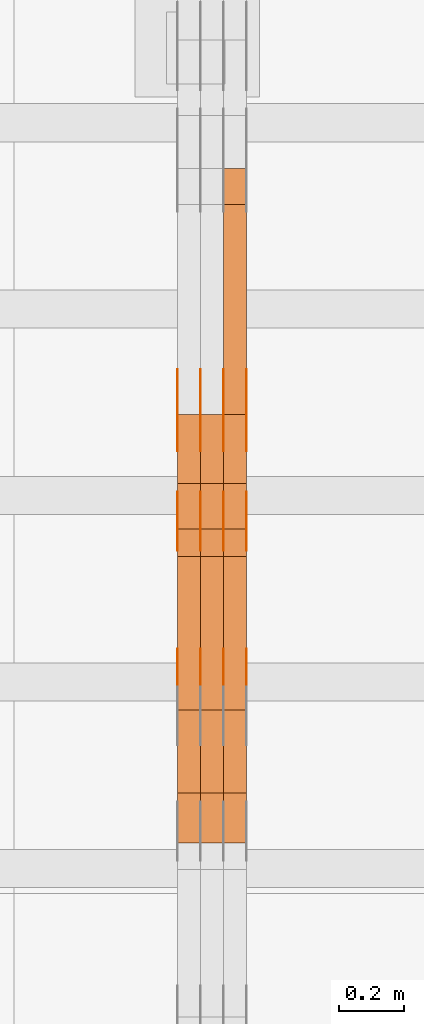
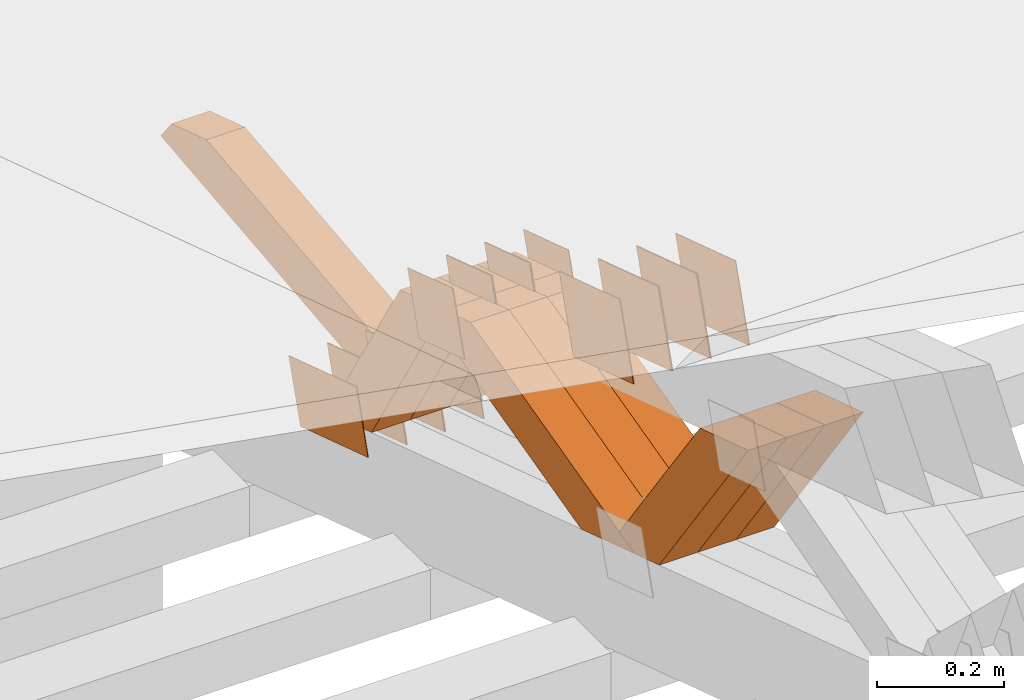
# One storey, part 241 of 385: 28 proxies.
"""IFC2X3 building model written with IfcOpenShell, lengths in millimetres."""

from ifc_helpers import new_model, entity, si_unit, converted_unit, derived_unit, direction, frame, origin, place, context, subcontext, project, spatial, polyline, outline, extrude, source, transform, mapped, material, type_object, type_shapes, element, save


model = new_model("IFC2X3")

# Units and contexts
model_context = context("Model", 3, precision=0.01, world=origin(), true_north=direction((6.12303176911189e-17, 1.0)))
body_context = subcontext(model_context, "Body", "Model", "MODEL_VIEW")
ifc_project = project(units=[si_unit("LENGTHUNIT", "METRE", prefix="MILLI"), si_unit("AREAUNIT", "SQUARE_METRE"), si_unit("VOLUMEUNIT", "CUBIC_METRE"), converted_unit("PLANEANGLEUNIT", "DEGREE", entity("IfcRatioMeasure", 0.0174532925199433), si_unit("PLANEANGLEUNIT", "RADIAN"), dimensions=[0, 0, 0, 0, 0, 0, 0]), si_unit("MASSUNIT", "GRAM", prefix="KILO"), derived_unit("MASSDENSITYUNIT", [(si_unit("MASSUNIT", "GRAM", prefix="KILO"), 1), (si_unit("LENGTHUNIT", "METRE"), -3)]), si_unit("TIMEUNIT", "SECOND"), si_unit("FREQUENCYUNIT", "HERTZ"), si_unit("THERMODYNAMICTEMPERATUREUNIT", "DEGREE_CELSIUS"), derived_unit("THERMALTRANSMITTANCEUNIT", [(si_unit("MASSUNIT", "GRAM", prefix="KILO"), 1), (si_unit("THERMODYNAMICTEMPERATUREUNIT", "KELVIN"), -1), (si_unit("TIMEUNIT", "SECOND"), -3)]), derived_unit("VOLUMETRICFLOWRATEUNIT", [(si_unit("LENGTHUNIT", "METRE"), 3), (si_unit("TIMEUNIT", "SECOND"), -1)]), si_unit("ELECTRICCURRENTUNIT", "AMPERE"), si_unit("ELECTRICVOLTAGEUNIT", "VOLT"), si_unit("POWERUNIT", "WATT"), si_unit("FORCEUNIT", "NEWTON", prefix="KILO"), si_unit("ILLUMINANCEUNIT", "LUX"), si_unit("LUMINOUSFLUXUNIT", "LUMEN"), si_unit("LUMINOUSINTENSITYUNIT", "CANDELA"), derived_unit("USERDEFINED", [(si_unit("MASSUNIT", "GRAM", prefix="KILO"), -1), (si_unit("LENGTHUNIT", "METRE"), -2), (si_unit("TIMEUNIT", "SECOND"), 3), (si_unit("LUMINOUSFLUXUNIT", "LUMEN"), 1)]), derived_unit("LINEARVELOCITYUNIT", [(si_unit("LENGTHUNIT", "METRE"), 1), (si_unit("TIMEUNIT", "SECOND"), -1)]), si_unit("PRESSUREUNIT", "PASCAL"), derived_unit("USERDEFINED", [(si_unit("LENGTHUNIT", "METRE"), -2), (si_unit("MASSUNIT", "GRAM", prefix="KILO"), 1), (si_unit("TIMEUNIT", "SECOND"), -2)])], contexts=[model_context])

# Site, building, storey
site_placement = place(None, origin())
site = spatial("IfcSite", under=ifc_project, at=site_placement, CompositionType="ELEMENT")
building_placement = place(site_placement, origin())
building = spatial("IfcBuilding", under=site, at=building_placement, CompositionType="ELEMENT")
storey_placement = place(building_placement, origin())
storey = spatial("IfcBuildingStorey", under=building, at=storey_placement, Name="Default", CompositionType="ELEMENT", Elevation=0.0)

# Proxies
ifc_material_1 = material(Name="IfcSurfaceStyle #366594")
building_element_proxy_type_1 = type_object("IfcBuildingElementProxyType", PredefinedType="NOTDEFINED", material=ifc_material_1)
shared_shape_1 = source(origin(), body_context, "Body", "SweptSolid", [
    extrude(outline(polyline([(-75.0001163267648, -60.0000309352964), (75.0001029049313, -60.0000309352964), (75.0001068963143, 60.0000309352964), (-75.0000934744807, 60.0000309352964), (-75.0001163267648, -60.0000309352964)])), frame((75.0001143227305, 60.0000309352964, 0.0), z_axis=(0.0, 0.0, 1.0), x_axis=(-1.0, 0.0, 0.0)), (0.0, 0.0, 1.0), 1.3),
])
type_shapes(building_element_proxy_type_1, [shared_shape_1])
proxy_1_placement = place(building_placement, frame((30386.3, 24935.0160969462, 827.753587802763), z_axis=(-1.0, 0.0, 0.0), x_axis=(0.0, -0.951056516295154, 0.309016994374948)))
element("IfcBuildingElementProxy", 1, at=proxy_1_placement, inside=storey, type_object=building_element_proxy_type_1, material=ifc_material_1, context=body_context, shape_type="MappedRepresentation", body=[
    mapped(shared_shape_1, transform((0.0, 0.0, 0.0), scale=1.0)),
])
ifc_material_2 = material(Name="IfcSurfaceStyle #366537")
building_element_proxy_type_2 = type_object("IfcBuildingElementProxyType", PredefinedType="NOTDEFINED", material=ifc_material_2)
shared_shape_2 = source(origin(), body_context, "Body", "SweptSolid", [
    extrude(outline(polyline([(-75.0001163267648, -60.0000309352964), (75.0001029049313, -60.0000309352964), (75.0001068963143, 60.0000309352964), (-75.0000934744807, 60.0000309352964), (-75.0001163267648, -60.0000309352964)])), frame((75.0001143227305, 60.0000309352964, 0.0), z_axis=(0.0, 0.0, 1.0), x_axis=(-1.0, 0.0, 0.0)), (0.0, 0.0, 1.0), 1.3),
])
type_shapes(building_element_proxy_type_2, [shared_shape_2])
proxy_2_placement = place(building_placement, frame((30315.0, 24935.0160969462, 827.753587802763), z_axis=(-1.0, 0.0, 0.0), x_axis=(0.0, -0.951056516295154, 0.309016994374948)))
element("IfcBuildingElementProxy", 2, at=proxy_2_placement, inside=storey, type_object=building_element_proxy_type_2, material=ifc_material_2, context=body_context, shape_type="MappedRepresentation", body=[
    mapped(shared_shape_2, transform((0.0, 0.0, 0.0), scale=1.0)),
])
ifc_material_3 = material(Name="IfcSurfaceStyle #366480")
building_element_proxy_type_3 = type_object("IfcBuildingElementProxyType", PredefinedType="NOTDEFINED", material=ifc_material_3)
shared_shape_3 = source(origin(), body_context, "Body", "SweptSolid", [
    extrude(outline(polyline([(-75.0001163267648, -60.0000309352964), (75.0001029049313, -60.0000309352964), (75.0001068963143, 60.0000309352964), (-75.0000934744807, 60.0000309352964), (-75.0001163267648, -60.0000309352964)])), frame((75.0001143227305, 60.0000309352964, 0.0), z_axis=(0.0, 0.0, 1.0), x_axis=(-1.0, 0.0, 0.0)), (0.0, 0.0, 1.0), 1.3),
])
type_shapes(building_element_proxy_type_3, [shared_shape_3])
proxy_3_placement = place(building_placement, frame((30316.3, 24935.0160969462, 827.753587802763), z_axis=(-1.0, 0.0, 0.0), x_axis=(0.0, -0.951056516295154, 0.309016994374948)))
element("IfcBuildingElementProxy", 3, at=proxy_3_placement, inside=storey, type_object=building_element_proxy_type_3, material=ifc_material_3, context=body_context, shape_type="MappedRepresentation", body=[
    mapped(shared_shape_3, transform((0.0, 0.0, 0.0), scale=1.0)),
])
ifc_material_4 = material(Name="IfcSurfaceStyle #366423")
building_element_proxy_type_4 = type_object("IfcBuildingElementProxyType", PredefinedType="NOTDEFINED", material=ifc_material_4)
shared_shape_4 = source(origin(), body_context, "Body", "SweptSolid", [
    extrude(outline(polyline([(-75.0001163267648, -60.0000309352964), (75.0001029049313, -60.0000309352964), (75.0001068963143, 60.0000309352964), (-75.0000934744807, 60.0000309352964), (-75.0001163267648, -60.0000309352964)])), frame((75.0001143227305, 60.0000309352964, 0.0), z_axis=(0.0, 0.0, 1.0), x_axis=(-1.0, 0.0, 0.0)), (0.0, 0.0, 1.0), 1.29999999999999),
])
type_shapes(building_element_proxy_type_4, [shared_shape_4])
proxy_4_placement = place(building_placement, frame((30245.0, 24935.0160969462, 827.753587802763), z_axis=(-1.0, 0.0, 0.0), x_axis=(0.0, -0.951056516295154, 0.309016994374948)))
element("IfcBuildingElementProxy", 4, at=proxy_4_placement, inside=storey, type_object=building_element_proxy_type_4, material=ifc_material_4, context=body_context, shape_type="MappedRepresentation", body=[
    mapped(shared_shape_4, transform((0.0, 0.0, 0.0), scale=1.0)),
])
ifc_material_5 = material(Name="IfcSurfaceStyle #366366")
building_element_proxy_type_5 = type_object("IfcBuildingElementProxyType", PredefinedType="NOTDEFINED", material=ifc_material_5)
shared_shape_5 = source(origin(), body_context, "Body", "SweptSolid", [
    extrude(outline(polyline([(-75.0001163267648, -60.0000309352964), (75.0001029049313, -60.0000309352964), (75.0001068963143, 60.0000309352964), (-75.0000934744807, 60.0000309352964), (-75.0001163267648, -60.0000309352964)])), frame((75.0001143227305, 60.0000309352964, 0.0), z_axis=(0.0, 0.0, 1.0), x_axis=(-1.0, 0.0, 0.0)), (0.0, 0.0, 1.0), 1.29999999999999),
])
type_shapes(building_element_proxy_type_5, [shared_shape_5])
proxy_5_placement = place(building_placement, frame((30246.3, 24935.0160969462, 827.753587802763), z_axis=(-1.0, 0.0, 0.0), x_axis=(0.0, -0.951056516295154, 0.309016994374948)))
element("IfcBuildingElementProxy", 5, at=proxy_5_placement, inside=storey, type_object=building_element_proxy_type_5, material=ifc_material_5, context=body_context, shape_type="MappedRepresentation", body=[
    mapped(shared_shape_5, transform((0.0, 0.0, 0.0), scale=1.0)),
])
ifc_material_6 = material(Name="IfcSurfaceStyle #366309")
building_element_proxy_type_6 = type_object("IfcBuildingElementProxyType", PredefinedType="NOTDEFINED", material=ifc_material_6)
shared_shape_6 = source(origin(), body_context, "Body", "SweptSolid", [
    extrude(outline(polyline([(-75.0001163267648, -60.0000309352964), (75.0001029049313, -60.0000309352964), (75.0001068963143, 60.0000309352964), (-75.0000934744807, 60.0000309352964), (-75.0001163267648, -60.0000309352964)])), frame((75.0001143227305, 60.0000309352964, 0.0), z_axis=(0.0, 0.0, 1.0), x_axis=(-1.0, 0.0, 0.0)), (0.0, 0.0, 1.0), 1.29999999999999),
])
type_shapes(building_element_proxy_type_6, [shared_shape_6])
proxy_6_placement = place(building_placement, frame((30175.0, 24935.0160969462, 827.753587802763), z_axis=(-1.0, 0.0, 0.0), x_axis=(0.0, -0.951056516295154, 0.309016994374948)))
element("IfcBuildingElementProxy", 6, at=proxy_6_placement, inside=storey, type_object=building_element_proxy_type_6, material=ifc_material_6, context=body_context, shape_type="MappedRepresentation", body=[
    mapped(shared_shape_6, transform((0.0, 0.0, 0.0), scale=1.0)),
])
ifc_material_7 = material(Name="IfcSurfaceStyle #366252")
building_element_proxy_type_7 = type_object("IfcBuildingElementProxyType", PredefinedType="NOTDEFINED", material=ifc_material_7)
shared_shape_7 = source(origin(), body_context, "Body", "SweptSolid", [
    extrude(outline(polyline([(-112.50003853564, -60.0000121429077), (112.50002982902, -60.0000121429077), (112.500043250865, 60.0000121429077), (-112.500034544245, 60.0000121429077), (-112.50003853564, -60.0000121429077)])), frame((112.500056021398, 60.0000121429077, 0.0), z_axis=(0.0, 0.0, 1.0), x_axis=(-1.0, 0.0, 0.0)), (0.0, 0.0, 1.0), 1.3),
])
type_shapes(building_element_proxy_type_7, [shared_shape_7])
proxy_7_placement = place(building_placement, frame((30386.3, 25310.2182710494, 430.675738123044), z_axis=(-1.0, 0.0, 0.0), x_axis=(0.0, -0.951056516295124, 0.309016994375039)))
element("IfcBuildingElementProxy", 7, at=proxy_7_placement, inside=storey, type_object=building_element_proxy_type_7, material=ifc_material_7, context=body_context, shape_type="MappedRepresentation", body=[
    mapped(shared_shape_7, transform((0.0, 0.0, 0.0), scale=1.0)),
])
ifc_material_8 = material(Name="IfcSurfaceStyle #366195")
building_element_proxy_type_8 = type_object("IfcBuildingElementProxyType", PredefinedType="NOTDEFINED", material=ifc_material_8)
shared_shape_8 = source(origin(), body_context, "Body", "SweptSolid", [
    extrude(outline(polyline([(-112.50003853564, -60.0000121429077), (112.50002982902, -60.0000121429077), (112.500043250865, 60.0000121429077), (-112.500034544245, 60.0000121429077), (-112.50003853564, -60.0000121429077)])), frame((112.500056021398, 60.0000121429077, 0.0), z_axis=(0.0, 0.0, 1.0), x_axis=(-1.0, 0.0, 0.0)), (0.0, 0.0, 1.0), 1.3),
])
type_shapes(building_element_proxy_type_8, [shared_shape_8])
proxy_8_placement = place(building_placement, frame((30315.0, 25310.2182710494, 430.675738123044), z_axis=(-1.0, 0.0, 0.0), x_axis=(0.0, -0.951056516295124, 0.309016994375039)))
element("IfcBuildingElementProxy", 8, at=proxy_8_placement, inside=storey, type_object=building_element_proxy_type_8, material=ifc_material_8, context=body_context, shape_type="MappedRepresentation", body=[
    mapped(shared_shape_8, transform((0.0, 0.0, 0.0), scale=1.0)),
])
ifc_material_9 = material(Name="IfcSurfaceStyle #366138")
building_element_proxy_type_9 = type_object("IfcBuildingElementProxyType", PredefinedType="NOTDEFINED", material=ifc_material_9)
shared_shape_9 = source(origin(), body_context, "Body", "SweptSolid", [
    extrude(outline(polyline([(-112.50003853564, -60.0000121429077), (112.50002982902, -60.0000121429077), (112.500043250865, 60.0000121429077), (-112.500034544245, 60.0000121429077), (-112.50003853564, -60.0000121429077)])), frame((112.500056021398, 60.0000121429077, 0.0), z_axis=(0.0, 0.0, 1.0), x_axis=(-1.0, 0.0, 0.0)), (0.0, 0.0, 1.0), 1.3),
])
type_shapes(building_element_proxy_type_9, [shared_shape_9])
proxy_9_placement = place(building_placement, frame((30316.3, 25310.2182710494, 430.675738123044), z_axis=(-1.0, 0.0, 0.0), x_axis=(0.0, -0.951056516295124, 0.309016994375039)))
element("IfcBuildingElementProxy", 9, at=proxy_9_placement, inside=storey, type_object=building_element_proxy_type_9, material=ifc_material_9, context=body_context, shape_type="MappedRepresentation", body=[
    mapped(shared_shape_9, transform((0.0, 0.0, 0.0), scale=1.0)),
])
ifc_material_10 = material(Name="IfcSurfaceStyle #366081")
building_element_proxy_type_10 = type_object("IfcBuildingElementProxyType", PredefinedType="NOTDEFINED", material=ifc_material_10)
shared_shape_10 = source(origin(), body_context, "Body", "SweptSolid", [
    extrude(outline(polyline([(-112.50003853564, -60.0000121429077), (112.50002982902, -60.0000121429077), (112.500043250865, 60.0000121429077), (-112.500034544245, 60.0000121429077), (-112.50003853564, -60.0000121429077)])), frame((112.500056021398, 60.0000121429077, 0.0), z_axis=(0.0, 0.0, 1.0), x_axis=(-1.0, 0.0, 0.0)), (0.0, 0.0, 1.0), 1.29999999999998),
])
type_shapes(building_element_proxy_type_10, [shared_shape_10])
proxy_10_placement = place(building_placement, frame((30245.0, 25310.2182710494, 430.675738123044), z_axis=(-1.0, 0.0, 0.0), x_axis=(0.0, -0.951056516295124, 0.309016994375039)))
element("IfcBuildingElementProxy", 10, at=proxy_10_placement, inside=storey, type_object=building_element_proxy_type_10, material=ifc_material_10, context=body_context, shape_type="MappedRepresentation", body=[
    mapped(shared_shape_10, transform((0.0, 0.0, 0.0), scale=1.0)),
])
ifc_material_11 = material(Name="IfcSurfaceStyle #366024")
building_element_proxy_type_11 = type_object("IfcBuildingElementProxyType", PredefinedType="NOTDEFINED", material=ifc_material_11)
shared_shape_11 = source(origin(), body_context, "Body", "SweptSolid", [
    extrude(outline(polyline([(-112.50003853564, -60.0000121429077), (112.50002982902, -60.0000121429077), (112.500043250865, 60.0000121429077), (-112.500034544245, 60.0000121429077), (-112.50003853564, -60.0000121429077)])), frame((112.500056021398, 60.0000121429077, 0.0), z_axis=(0.0, 0.0, 1.0), x_axis=(-1.0, 0.0, 0.0)), (0.0, 0.0, 1.0), 1.29999999999998),
])
type_shapes(building_element_proxy_type_11, [shared_shape_11])
proxy_11_placement = place(building_placement, frame((30246.3, 25310.2182710494, 430.675738123044), z_axis=(-1.0, 0.0, 0.0), x_axis=(0.0, -0.951056516295124, 0.309016994375039)))
element("IfcBuildingElementProxy", 11, at=proxy_11_placement, inside=storey, type_object=building_element_proxy_type_11, material=ifc_material_11, context=body_context, shape_type="MappedRepresentation", body=[
    mapped(shared_shape_11, transform((0.0, 0.0, 0.0), scale=1.0)),
])
ifc_material_12 = material(Name="IfcSurfaceStyle #365967")
building_element_proxy_type_12 = type_object("IfcBuildingElementProxyType", PredefinedType="NOTDEFINED", material=ifc_material_12)
shared_shape_12 = source(origin(), body_context, "Body", "SweptSolid", [
    extrude(outline(polyline([(-112.50003853564, -60.0000121429077), (112.50002982902, -60.0000121429077), (112.500043250865, 60.0000121429077), (-112.500034544245, 60.0000121429077), (-112.50003853564, -60.0000121429077)])), frame((112.500056021398, 60.0000121429077, 0.0), z_axis=(0.0, 0.0, 1.0), x_axis=(-1.0, 0.0, 0.0)), (0.0, 0.0, 1.0), 1.29999999999999),
])
type_shapes(building_element_proxy_type_12, [shared_shape_12])
proxy_12_placement = place(building_placement, frame((30175.0, 25310.2182710494, 430.675738123044), z_axis=(-1.0, 0.0, 0.0), x_axis=(0.0, -0.951056516295124, 0.309016994375039)))
element("IfcBuildingElementProxy", 12, at=proxy_12_placement, inside=storey, type_object=building_element_proxy_type_12, material=ifc_material_12, context=body_context, shape_type="MappedRepresentation", body=[
    mapped(shared_shape_12, transform((0.0, 0.0, 0.0), scale=1.0)),
])
ifc_material_13 = material(Name="IfcSurfaceStyle #364200")
building_element_proxy_type_13 = type_object("IfcBuildingElementProxyType", PredefinedType="NOTDEFINED", material=ifc_material_13)
shared_shape_13 = source(origin(), body_context, "Body", "SweptSolid", [
    extrude(outline(polyline([(-100.000009625089, -72.0000630699202), (100.000090167682, -72.0000630699202), (100.000009625089, 72.0000630699202), (-100.000090167682, 72.0000630699202), (-100.000009625089, -72.0000630699202)])), frame((100.000090167682, 72.0000630699202, 0.0), z_axis=(0.0, 0.0, 1.0), x_axis=(-1.0, 0.0, 0.0)), (0.0, 0.0, 1.0), 1.3),
])
type_shapes(building_element_proxy_type_13, [shared_shape_13])
proxy_13_placement = place(building_placement, frame((30386.3, 24447.7695802369, 1088.58717039832), z_axis=(-1.0, 0.0, 0.0), x_axis=(0.0, -0.951056516295154, 0.309016994374948)))
element("IfcBuildingElementProxy", 13, at=proxy_13_placement, inside=storey, type_object=building_element_proxy_type_13, material=ifc_material_13, context=body_context, shape_type="MappedRepresentation", body=[
    mapped(shared_shape_13, transform((0.0, 0.0, 0.0), scale=1.0)),
])
ifc_material_14 = material(Name="IfcSurfaceStyle #364143")
building_element_proxy_type_14 = type_object("IfcBuildingElementProxyType", PredefinedType="NOTDEFINED", material=ifc_material_14)
shared_shape_14 = source(origin(), body_context, "Body", "SweptSolid", [
    extrude(outline(polyline([(-100.000009625089, -72.0000630699202), (100.000090167682, -72.0000630699202), (100.000009625089, 72.0000630699202), (-100.000090167682, 72.0000630699202), (-100.000009625089, -72.0000630699202)])), frame((100.000090167682, 72.0000630699202, 0.0), z_axis=(0.0, 0.0, 1.0), x_axis=(-1.0, 0.0, 0.0)), (0.0, 0.0, 1.0), 1.3),
])
type_shapes(building_element_proxy_type_14, [shared_shape_14])
proxy_14_placement = place(building_placement, frame((30315.0, 24447.7695802369, 1088.58717039832), z_axis=(-1.0, 0.0, 0.0), x_axis=(0.0, -0.951056516295154, 0.309016994374948)))
element("IfcBuildingElementProxy", 14, at=proxy_14_placement, inside=storey, type_object=building_element_proxy_type_14, material=ifc_material_14, context=body_context, shape_type="MappedRepresentation", body=[
    mapped(shared_shape_14, transform((0.0, 0.0, 0.0), scale=1.0)),
])
ifc_material_15 = material(Name="IfcSurfaceStyle #364086")
building_element_proxy_type_15 = type_object("IfcBuildingElementProxyType", PredefinedType="NOTDEFINED", material=ifc_material_15)
shared_shape_15 = source(origin(), body_context, "Body", "SweptSolid", [
    extrude(outline(polyline([(-100.000009625089, -72.0000630699202), (100.000090167682, -72.0000630699202), (100.000009625089, 72.0000630699202), (-100.000090167682, 72.0000630699202), (-100.000009625089, -72.0000630699202)])), frame((100.000090167682, 72.0000630699202, 0.0), z_axis=(0.0, 0.0, 1.0), x_axis=(-1.0, 0.0, 0.0)), (0.0, 0.0, 1.0), 1.3),
])
type_shapes(building_element_proxy_type_15, [shared_shape_15])
proxy_15_placement = place(building_placement, frame((30316.3, 24447.7695802369, 1088.58717039832), z_axis=(-1.0, 0.0, 0.0), x_axis=(0.0, -0.951056516295154, 0.309016994374948)))
element("IfcBuildingElementProxy", 15, at=proxy_15_placement, inside=storey, type_object=building_element_proxy_type_15, material=ifc_material_15, context=body_context, shape_type="MappedRepresentation", body=[
    mapped(shared_shape_15, transform((0.0, 0.0, 0.0), scale=1.0)),
])
ifc_material_16 = material(Name="IfcSurfaceStyle #364029")
building_element_proxy_type_16 = type_object("IfcBuildingElementProxyType", PredefinedType="NOTDEFINED", material=ifc_material_16)
shared_shape_16 = source(origin(), body_context, "Body", "SweptSolid", [
    extrude(outline(polyline([(-100.000009625089, -72.0000630699202), (100.000090167682, -72.0000630699202), (100.000009625089, 72.0000630699202), (-100.000090167682, 72.0000630699202), (-100.000009625089, -72.0000630699202)])), frame((100.000090167682, 72.0000630699202, 0.0), z_axis=(0.0, 0.0, 1.0), x_axis=(-1.0, 0.0, 0.0)), (0.0, 0.0, 1.0), 1.29999999999998),
])
type_shapes(building_element_proxy_type_16, [shared_shape_16])
proxy_16_placement = place(building_placement, frame((30245.0, 24447.7695802369, 1088.58717039832), z_axis=(-1.0, 0.0, 0.0), x_axis=(0.0, -0.951056516295154, 0.309016994374948)))
element("IfcBuildingElementProxy", 16, at=proxy_16_placement, inside=storey, type_object=building_element_proxy_type_16, material=ifc_material_16, context=body_context, shape_type="MappedRepresentation", body=[
    mapped(shared_shape_16, transform((0.0, 0.0, 0.0), scale=1.0)),
])
ifc_material_17 = material(Name="IfcSurfaceStyle #363972")
building_element_proxy_type_17 = type_object("IfcBuildingElementProxyType", PredefinedType="NOTDEFINED", material=ifc_material_17)
shared_shape_17 = source(origin(), body_context, "Body", "SweptSolid", [
    extrude(outline(polyline([(-100.000009625089, -72.0000630699202), (100.000090167682, -72.0000630699202), (100.000009625089, 72.0000630699202), (-100.000090167682, 72.0000630699202), (-100.000009625089, -72.0000630699202)])), frame((100.000090167682, 72.0000630699202, 0.0), z_axis=(0.0, 0.0, 1.0), x_axis=(-1.0, 0.0, 0.0)), (0.0, 0.0, 1.0), 1.29999999999998),
])
type_shapes(building_element_proxy_type_17, [shared_shape_17])
proxy_17_placement = place(building_placement, frame((30246.3, 24447.7695802369, 1088.58717039832), z_axis=(-1.0, 0.0, 0.0), x_axis=(0.0, -0.951056516295154, 0.309016994374948)))
element("IfcBuildingElementProxy", 17, at=proxy_17_placement, inside=storey, type_object=building_element_proxy_type_17, material=ifc_material_17, context=body_context, shape_type="MappedRepresentation", body=[
    mapped(shared_shape_17, transform((0.0, 0.0, 0.0), scale=1.0)),
])
ifc_material_18 = material(Name="IfcSurfaceStyle #363915")
building_element_proxy_type_18 = type_object("IfcBuildingElementProxyType", PredefinedType="NOTDEFINED", material=ifc_material_18)
shared_shape_18 = source(origin(), body_context, "Body", "SweptSolid", [
    extrude(outline(polyline([(-100.000009625089, -72.0000630699202), (100.000090167682, -72.0000630699202), (100.000009625089, 72.0000630699202), (-100.000090167682, 72.0000630699202), (-100.000009625089, -72.0000630699202)])), frame((100.000090167682, 72.0000630699202, 0.0), z_axis=(0.0, 0.0, 1.0), x_axis=(-1.0, 0.0, 0.0)), (0.0, 0.0, 1.0), 1.29999999999999),
])
type_shapes(building_element_proxy_type_18, [shared_shape_18])
proxy_18_placement = place(building_placement, frame((30175.0, 24447.7695802369, 1088.58717039832), z_axis=(-1.0, 0.0, 0.0), x_axis=(0.0, -0.951056516295154, 0.309016994374948)))
element("IfcBuildingElementProxy", 18, at=proxy_18_placement, inside=storey, type_object=building_element_proxy_type_18, material=ifc_material_18, context=body_context, shape_type="MappedRepresentation", body=[
    mapped(shared_shape_18, transform((0.0, 0.0, 0.0), scale=1.0)),
])
ifc_material_19 = material(Name="IfcSurfaceStyle #355002")
building_element_proxy_type_19 = type_object("IfcBuildingElementProxyType", Name="T1-W24 355000", PredefinedType="NOTDEFINED", material=ifc_material_19)
shared_shape_19 = source(origin(), body_context, "Body", "SweptSolid", [
    extrude(outline(polyline([(-215.642157779899, -47.4998772343114), (220.829928576248, -47.4998772343114), (202.182343865616, 6.34871490324596e-05), (137.545638852774, 47.4998454907369), (-344.915753514738, 47.4998454907369), (-215.642157779899, -47.4998772343114)])), frame((220.830079609702, 47.500154567531, 0.0), z_axis=(0.0, 0.0, 1.0), x_axis=(-1.0, 0.0, 0.0)), (0.0, 0.0, 1.0), 70.0),
])
type_shapes(building_element_proxy_type_19, [shared_shape_19])
proxy_19_placement = place(building_placement, frame((30385.0, 24227.7045444998, 781.019082122604), z_axis=(-1.0, 0.0, 0.0), x_axis=(0.0, -0.583381854128324, 0.812198012970851)))
element("IfcBuildingElementProxy", 19, at=proxy_19_placement, inside=storey, type_object=building_element_proxy_type_19, material=ifc_material_19, Name="T1-W24", context=body_context, shape_type="MappedRepresentation", body=[
    mapped(shared_shape_19, transform((0.0, 0.0, 0.0), scale=1.0)),
])
ifc_material_20 = material(Name="IfcSurfaceStyle #354936")
building_element_proxy_type_20 = type_object("IfcBuildingElementProxyType", Name="T1-W24 354934", PredefinedType="NOTDEFINED", material=ifc_material_20)
shared_shape_20 = source(origin(), body_context, "Body", "SweptSolid", [
    extrude(outline(polyline([(-215.642157779899, -47.4998772343114), (220.829928576248, -47.4998772343114), (202.182343865616, 6.34871490324596e-05), (137.545638852774, 47.4998454907369), (-344.915753514738, 47.4998454907369), (-215.642157779899, -47.4998772343114)])), frame((220.830079609702, 47.500154567531, 0.0), z_axis=(0.0, 0.0, 1.0), x_axis=(-1.0, 0.0, 0.0)), (0.0, 0.0, 1.0), 70.0),
])
type_shapes(building_element_proxy_type_20, [shared_shape_20])
proxy_20_placement = place(building_placement, frame((30315.0, 24227.7045444998, 781.019082122604), z_axis=(-1.0, 0.0, 0.0), x_axis=(0.0, -0.583381854128324, 0.812198012970851)))
element("IfcBuildingElementProxy", 20, at=proxy_20_placement, inside=storey, type_object=building_element_proxy_type_20, material=ifc_material_20, Name="T1-W24", context=body_context, shape_type="MappedRepresentation", body=[
    mapped(shared_shape_20, transform((0.0, 0.0, 0.0), scale=1.0)),
])
ifc_material_21 = material(Name="IfcSurfaceStyle #354870")
building_element_proxy_type_21 = type_object("IfcBuildingElementProxyType", Name="T1-W24 354868", PredefinedType="NOTDEFINED", material=ifc_material_21)
shared_shape_21 = source(origin(), body_context, "Body", "SweptSolid", [
    extrude(outline(polyline([(-215.642157779899, -47.4998772343114), (220.829928576248, -47.4998772343114), (202.182343865616, 6.34871490324596e-05), (137.545638852774, 47.4998454907369), (-344.915753514738, 47.4998454907369), (-215.642157779899, -47.4998772343114)])), frame((220.830079609702, 47.500154567531, 0.0), z_axis=(0.0, 0.0, 1.0), x_axis=(-1.0, 0.0, 0.0)), (0.0, 0.0, 1.0), 70.0),
])
type_shapes(building_element_proxy_type_21, [shared_shape_21])
proxy_21_placement = place(building_placement, frame((30245.0, 24227.7045444998, 781.019082122604), z_axis=(-1.0, 0.0, 0.0), x_axis=(0.0, -0.583381854128324, 0.812198012970851)))
element("IfcBuildingElementProxy", 21, at=proxy_21_placement, inside=storey, type_object=building_element_proxy_type_21, material=ifc_material_21, Name="T1-W24", context=body_context, shape_type="MappedRepresentation", body=[
    mapped(shared_shape_21, transform((0.0, 0.0, 0.0), scale=1.0)),
])
ifc_material_22 = material(Name="IfcSurfaceStyle #354606")
building_element_proxy_type_22 = type_object("IfcBuildingElementProxyType", Name="T1-W13 354604", PredefinedType="NOTDEFINED", material=ifc_material_22)
shared_shape_22 = source(origin(), body_context, "Body", "SweptSolid", [
    extrude(outline(polyline([(-384.339592151497, -47.5000055308246), (150.996422207105, -47.5000055308247), (226.265349299398, -4.29484466835994e-05), (240.878612116891, 47.500027005048), (-233.800791471897, 47.500027005048), (-384.339592151497, -47.5000055308246)])), frame((240.878612116891, 47.500027005048, 0.0), z_axis=(0.0, 0.0, 1.0), x_axis=(-1.0, 0.0, 0.0)), (0.0, 0.0, 1.0), 70.0),
])
type_shapes(building_element_proxy_type_22, [shared_shape_22])
proxy_22_placement = place(building_placement, frame((30385.0, 24884.765625, 885.749145507813), z_axis=(-1.0, 0.0, 0.0), x_axis=(0.0, -0.969210894563555, -0.246232089418326)))
element("IfcBuildingElementProxy", 22, at=proxy_22_placement, inside=storey, type_object=building_element_proxy_type_22, material=ifc_material_22, Name="T1-W13", context=body_context, shape_type="MappedRepresentation", body=[
    mapped(shared_shape_22, transform((0.0, 0.0, 0.0), scale=1.0)),
])
ifc_material_23 = material(Name="IfcSurfaceStyle #354540")
building_element_proxy_type_23 = type_object("IfcBuildingElementProxyType", Name="T1-W13 354538", PredefinedType="NOTDEFINED", material=ifc_material_23)
shared_shape_23 = source(origin(), body_context, "Body", "SweptSolid", [
    extrude(outline(polyline([(-384.339592151497, -47.5000055308246), (150.996422207105, -47.5000055308247), (226.265349299398, -4.29484466835994e-05), (240.878612116891, 47.500027005048), (-233.800791471897, 47.500027005048), (-384.339592151497, -47.5000055308246)])), frame((240.878612116891, 47.500027005048, 0.0), z_axis=(0.0, 0.0, 1.0), x_axis=(-1.0, 0.0, 0.0)), (0.0, 0.0, 1.0), 70.0),
])
type_shapes(building_element_proxy_type_23, [shared_shape_23])
proxy_23_placement = place(building_placement, frame((30315.0, 24884.765625, 885.749145507813), z_axis=(-1.0, 0.0, 0.0), x_axis=(0.0, -0.969210894563555, -0.246232089418326)))
element("IfcBuildingElementProxy", 23, at=proxy_23_placement, inside=storey, type_object=building_element_proxy_type_23, material=ifc_material_23, Name="T1-W13", context=body_context, shape_type="MappedRepresentation", body=[
    mapped(shared_shape_23, transform((0.0, 0.0, 0.0), scale=1.0)),
])
ifc_material_24 = material(Name="IfcSurfaceStyle #354474")
building_element_proxy_type_24 = type_object("IfcBuildingElementProxyType", Name="T1-W13 354472", PredefinedType="NOTDEFINED", material=ifc_material_24)
shared_shape_24 = source(origin(), body_context, "Body", "SweptSolid", [
    extrude(outline(polyline([(-384.339592151497, -47.5000055308246), (150.996422207105, -47.5000055308247), (226.265349299398, -4.29484466835994e-05), (240.878612116891, 47.500027005048), (-233.800791471897, 47.500027005048), (-384.339592151497, -47.5000055308246)])), frame((240.878612116891, 47.500027005048, 0.0), z_axis=(0.0, 0.0, 1.0), x_axis=(-1.0, 0.0, 0.0)), (0.0, 0.0, 1.0), 70.0),
])
type_shapes(building_element_proxy_type_24, [shared_shape_24])
proxy_24_placement = place(building_placement, frame((30245.0, 24884.765625, 885.749145507813), z_axis=(-1.0, 0.0, 0.0), x_axis=(0.0, -0.969210894563555, -0.246232089418326)))
element("IfcBuildingElementProxy", 24, at=proxy_24_placement, inside=storey, type_object=building_element_proxy_type_24, material=ifc_material_24, Name="T1-W13", context=body_context, shape_type="MappedRepresentation", body=[
    mapped(shared_shape_24, transform((0.0, 0.0, 0.0), scale=1.0)),
])
ifc_material_25 = material(Name="IfcSurfaceStyle #354210")
building_element_proxy_type_25 = type_object("IfcBuildingElementProxyType", Name="T1-W31 354208", PredefinedType="NOTDEFINED", material=ifc_material_25)
shared_shape_25 = source(origin(), body_context, "Body", "SweptSolid", [
    extrude(outline(polyline([(-201.245318299844, -47.5000121670808), (204.413774229459, -47.5000121670808), (182.034306640891, 5.35692244583164e-05), (126.70380769348, 47.4999853824686), (-311.906570263987, 47.4999853824686), (-201.245318299844, -47.5000121670808)])), frame((204.413774229459, 47.5002684334588, 0.0), z_axis=(0.0, 0.0, 1.0), x_axis=(-1.0, 0.0, 0.0)), (0.0, 0.0, 1.0), 70.0),
])
type_shapes(building_element_proxy_type_25, [shared_shape_25])
proxy_25_placement = place(building_placement, frame((30385.0, 25127.5652647985, 487.27008059185), z_axis=(-1.0, 0.0, 0.0), x_axis=(0.0, -0.520333970303023, 0.853962855953755)))
element("IfcBuildingElementProxy", 25, at=proxy_25_placement, inside=storey, type_object=building_element_proxy_type_25, material=ifc_material_25, Name="T1-W31", context=body_context, shape_type="MappedRepresentation", body=[
    mapped(shared_shape_25, transform((0.0, 0.0, 0.0), scale=1.0)),
])
ifc_material_26 = material(Name="IfcSurfaceStyle #354144")
building_element_proxy_type_26 = type_object("IfcBuildingElementProxyType", Name="T1-W31 354142", PredefinedType="NOTDEFINED", material=ifc_material_26)
shared_shape_26 = source(origin(), body_context, "Body", "SweptSolid", [
    extrude(outline(polyline([(-201.245318299844, -47.5000121670808), (204.413774229459, -47.5000121670808), (182.034306640891, 5.35692244583164e-05), (126.70380769348, 47.4999853824686), (-311.906570263987, 47.4999853824686), (-201.245318299844, -47.5000121670808)])), frame((204.413774229459, 47.5002684334588, 0.0), z_axis=(0.0, 0.0, 1.0), x_axis=(-1.0, 0.0, 0.0)), (0.0, 0.0, 1.0), 70.0),
])
type_shapes(building_element_proxy_type_26, [shared_shape_26])
proxy_26_placement = place(building_placement, frame((30315.0, 25127.5652647985, 487.27008059185), z_axis=(-1.0, 0.0, 0.0), x_axis=(0.0, -0.520333970303023, 0.853962855953755)))
element("IfcBuildingElementProxy", 26, at=proxy_26_placement, inside=storey, type_object=building_element_proxy_type_26, material=ifc_material_26, Name="T1-W31", context=body_context, shape_type="MappedRepresentation", body=[
    mapped(shared_shape_26, transform((0.0, 0.0, 0.0), scale=1.0)),
])
ifc_material_27 = material(Name="IfcSurfaceStyle #354078")
building_element_proxy_type_27 = type_object("IfcBuildingElementProxyType", Name="T1-W31 354076", PredefinedType="NOTDEFINED", material=ifc_material_27)
shared_shape_27 = source(origin(), body_context, "Body", "SweptSolid", [
    extrude(outline(polyline([(-201.245318299844, -47.5000121670808), (204.413774229459, -47.5000121670808), (182.034306640891, 5.35692244583164e-05), (126.70380769348, 47.4999853824686), (-311.906570263987, 47.4999853824686), (-201.245318299844, -47.5000121670808)])), frame((204.413774229459, 47.5002684334588, 0.0), z_axis=(0.0, 0.0, 1.0), x_axis=(-1.0, 0.0, 0.0)), (0.0, 0.0, 1.0), 70.0),
])
type_shapes(building_element_proxy_type_27, [shared_shape_27])
proxy_27_placement = place(building_placement, frame((30245.0, 25127.5652647985, 487.27008059185), z_axis=(-1.0, 0.0, 0.0), x_axis=(0.0, -0.520333970303023, 0.853962855953755)))
element("IfcBuildingElementProxy", 27, at=proxy_27_placement, inside=storey, type_object=building_element_proxy_type_27, material=ifc_material_27, Name="T1-W31", context=body_context, shape_type="MappedRepresentation", body=[
    mapped(shared_shape_27, transform((0.0, 0.0, 0.0), scale=1.0)),
])
ifc_material_28 = material(Name="IfcSurfaceStyle #353814")
building_element_proxy_type_28 = type_object("IfcBuildingElementProxyType", Name="T1-W4 353812", PredefinedType="NOTDEFINED", material=ifc_material_28)
shared_shape_28 = source(origin(), body_context, "Body", "SweptSolid", [
    extrude(outline(polyline([(-510.077325435179, -47.4999981284922), (188.854793418912, -47.4999981284922), (294.906688207675, 1.67015383116809e-05), (324.289382923648, 47.499989777723), (-297.973539115057, 47.4999897777231), (-510.077325435179, -47.4999981284922)])), frame((324.289382923648, 47.5000278316275, 0.0), z_axis=(0.0, 0.0, 1.0), x_axis=(-1.0, 0.0, 0.0)), (0.0, 0.0, 1.0), 70.0),
])
type_shapes(building_element_proxy_type_28, [shared_shape_28])
proxy_28_placement = place(building_placement, frame((30385.0, 25996.2241251556, 525.69905884318), z_axis=(-1.0, 0.0, 0.0), x_axis=(0.0, -0.994287125203057, -0.106738524701444)))
element("IfcBuildingElementProxy", 28, at=proxy_28_placement, inside=storey, type_object=building_element_proxy_type_28, material=ifc_material_28, Name="T1-W4", context=body_context, shape_type="MappedRepresentation", body=[
    mapped(shared_shape_28, transform((0.0, 0.0, 0.0), scale=1.0)),
])

save(model, "model.ifc")
